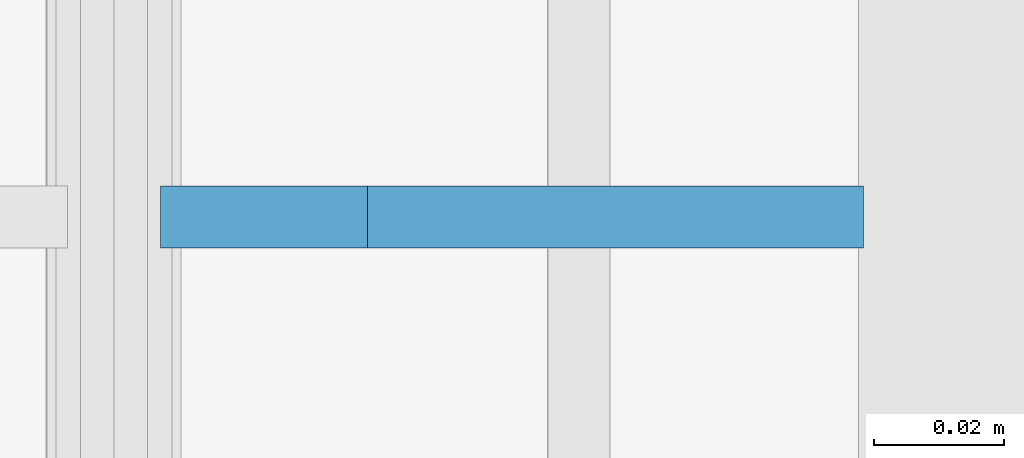
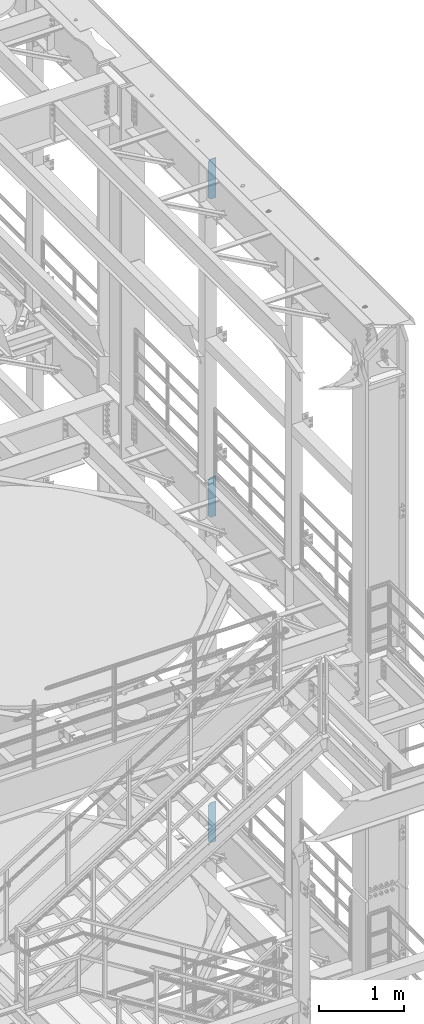
# One storey, part 1671 of 1876: 3 plates, 3 elements without a shape of their own.
"""IFC2X3 building model written with IfcOpenShell, lengths in millimetres."""

from ifc_helpers import new_model, si_unit, frame, origin_with_axes, place, context, subcontext, project, spatial, faceted_brep, material, type_object, element, aggregate, save


model = new_model("IFC2X3")

# Units and contexts
model_context = context("Model", 3, precision=1e-05, world=origin_with_axes())
body_context = subcontext(model_context, "Body", "Model", "MODEL_VIEW")
ifc_project = project(units=[si_unit("LENGTHUNIT", "METRE", prefix="MILLI"), si_unit("AREAUNIT", "SQUARE_METRE"), si_unit("VOLUMEUNIT", "CUBIC_METRE"), si_unit("MASSUNIT", "GRAM", prefix="KILO"), si_unit("TIMEUNIT", "SECOND"), si_unit("PLANEANGLEUNIT", "RADIAN"), si_unit("SOLIDANGLEUNIT", "STERADIAN"), si_unit("THERMODYNAMICTEMPERATUREUNIT", "DEGREE_CELSIUS"), si_unit("LUMINOUSINTENSITYUNIT", "LUMEN")], contexts=[model_context])

# Site, building, storey
site_placement = place(None, origin_with_axes())
site = spatial("IfcSite", under=ifc_project, at=site_placement, CompositionType="ELEMENT")
building_placement = place(site_placement, origin_with_axes())
building = spatial("IfcBuilding", under=site, at=building_placement, Name="Undefined", CompositionType="ELEMENT")
storey_placement = place(building_placement, origin_with_axes())
storey = spatial("IfcBuildingStorey", under=building, at=storey_placement, Name="Undefined", CompositionType="ELEMENT", Elevation=0.0)

# Assembly, plate
assembly_1_placement = place(storey_placement, origin_with_axes())
assembly_1 = element("IfcElementAssembly", 1, at=assembly_1_placement, inside=storey, Name="BEAM", AssemblyPlace="NOTDEFINED", PredefinedType="RIGID_FRAME")
ifc_material = material(Name="STEEL/A36")
plate_type = type_object("IfcPlateType", PredefinedType="NOTDEFINED")
plate_1_placement = place(assembly_1_placement, frame((7735.09375, -508.0, 21958.3), z_axis=(0.0, 0.0, 1.0), x_axis=(-1.0, 0.0, 0.0)))
plate_1 = element("IfcPlate", 2, at=plate_1_placement, type_object=plate_type, material=ifc_material, Name="PLATE", context=body_context, shape_type="Brep", body=[
    faceted_brep([(0.0, -4.76249999999982, 0.0), (0.0, -4.76249999999982, 571.5), (0.0, 4.76249999999982, 571.5), (0.0, 4.76249999999982, 0.0), (76.1999969482422, -4.76249999999982, 571.5), (76.1999969482422, 4.76249999999982, 571.5), (107.949996948242, -4.76249999999982, 539.75), (107.949996948242, 4.76249999999982, 539.75), (107.949996948242, -4.76249999999982, 31.75), (107.949996948242, 4.76249999999982, 31.75), (76.1999969482422, -4.76250000000073, 0.0), (76.1999969482422, 4.76250000000073, 0.0)], [[[0, 1, 2, 3]], [[1, 4, 5, 2]], [[4, 6, 7, 5]], [[6, 8, 9, 7]], [[8, 10, 11, 9]], [[10, 0, 3, 11]], [[5, 7, 9, 11, 3, 2]], [[10, 8, 6, 4, 1, 0]]]),
])
aggregate(assembly_1, [plate_1])

assembly_2_placement = place(storey_placement, origin_with_axes())
assembly_2 = element("IfcElementAssembly", 3, at=assembly_2_placement, inside=storey, Name="BEAM", AssemblyPlace="NOTDEFINED", PredefinedType="RIGID_FRAME")
plate_2_placement = place(assembly_2_placement, frame((7735.09374694824, -508.0, 17386.3), z_axis=(0.0, 0.0, 1.0), x_axis=(-1.0, 0.0, 0.0)))
plate_2 = element("IfcPlate", 4, at=plate_2_placement, type_object=plate_type, material=ifc_material, Name="PLATE", context=body_context, shape_type="Brep", body=[
    faceted_brep([(0.0, -4.76249999999982, 0.0), (0.0, -4.76249999999982, 571.5), (0.0, 4.76249999999982, 571.5), (0.0, 4.76249999999982, 0.0), (76.1999969482422, -4.76249999999982, 571.5), (76.1999969482422, 4.76249999999982, 571.5), (107.949996948242, -4.76249999999982, 539.75), (107.949996948242, 4.76249999999982, 539.75), (107.949996948242, -4.76249999999982, 31.75), (107.949996948242, 4.76249999999982, 31.75), (76.1999969482422, -4.76250000000073, 0.0), (76.1999969482422, 4.76250000000073, 0.0)], [[[0, 1, 2, 3]], [[1, 4, 5, 2]], [[4, 6, 7, 5]], [[6, 8, 9, 7]], [[8, 10, 11, 9]], [[10, 0, 3, 11]], [[5, 7, 9, 11, 3, 2]], [[10, 8, 6, 4, 1, 0]]]),
])
aggregate(assembly_2, [plate_2])

assembly_3_placement = place(storey_placement, origin_with_axes())
assembly_3 = element("IfcElementAssembly", 5, at=assembly_3_placement, inside=storey, Name="BEAM", AssemblyPlace="NOTDEFINED", PredefinedType="RIGID_FRAME")
plate_3_placement = place(assembly_3_placement, frame((7735.09375, -508.0, 12712.7), z_axis=(0.0, 0.0, 1.0), x_axis=(-1.0, 0.0, 0.0)))
plate_3 = element("IfcPlate", 6, at=plate_3_placement, type_object=plate_type, material=ifc_material, Name="PLATE", context=body_context, shape_type="Brep", body=[
    faceted_brep([(0.0, -4.76249999999982, 0.0), (0.0, -4.76249999999982, 571.5), (0.0, 4.76249999999982, 571.5), (0.0, 4.76249999999982, 0.0), (76.1999969482422, -4.76249999999982, 571.5), (76.1999969482422, 4.76249999999982, 571.5), (107.949996948242, -4.76249999999982, 539.75), (107.949996948242, 4.76249999999982, 539.75), (107.949996948242, -4.76249999999982, 31.75), (107.949996948242, 4.76249999999982, 31.75), (76.1999969482422, -4.76250000000073, 0.0), (76.1999969482422, 4.76250000000073, 0.0)], [[[0, 1, 2, 3]], [[1, 4, 5, 2]], [[4, 6, 7, 5]], [[6, 8, 9, 7]], [[8, 10, 11, 9]], [[10, 0, 3, 11]], [[5, 7, 9, 11, 3, 2]], [[10, 8, 6, 4, 1, 0]]]),
])
aggregate(assembly_3, [plate_3])

save(model, "model.ifc")
